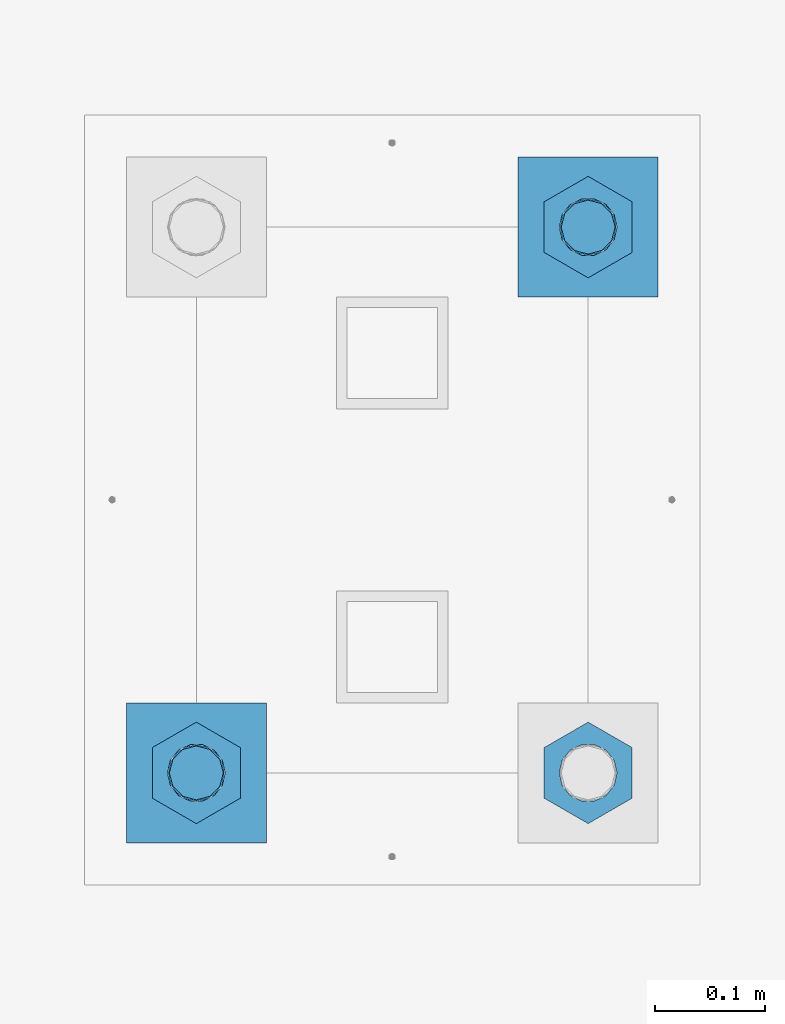
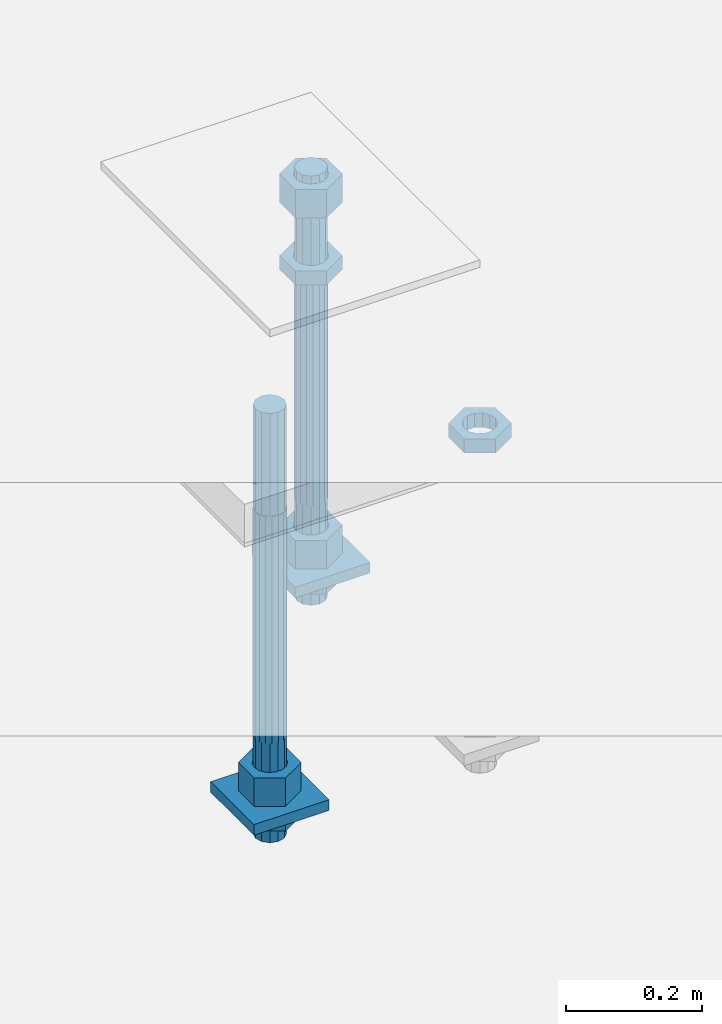
# One storey, part 2630 of 3843: 11 beams, 1 element without a shape of its own.
"""IFC2X3 building model written with IfcOpenShell, lengths in millimetres."""

from ifc_helpers import new_model, si_unit, frame, origin_with_axes, place, context, subcontext, project, spatial, faceted_brep, material, type_object, element, aggregate, save


model = new_model("IFC2X3")

# Units and contexts
model_context = context("Model", 3, precision=1e-05, world=origin_with_axes())
body_context = subcontext(model_context, "Body", "Model", "MODEL_VIEW")
ifc_project = project(units=[si_unit("LENGTHUNIT", "METRE", prefix="MILLI"), si_unit("AREAUNIT", "SQUARE_METRE"), si_unit("VOLUMEUNIT", "CUBIC_METRE"), si_unit("MASSUNIT", "GRAM", prefix="KILO"), si_unit("TIMEUNIT", "SECOND"), si_unit("PLANEANGLEUNIT", "RADIAN"), si_unit("SOLIDANGLEUNIT", "STERADIAN"), si_unit("THERMODYNAMICTEMPERATUREUNIT", "DEGREE_CELSIUS"), si_unit("LUMINOUSINTENSITYUNIT", "LUMEN")], contexts=[model_context])

# Site, building, storey
site_placement = place(None, origin_with_axes())
site = spatial("IfcSite", under=ifc_project, at=site_placement, CompositionType="ELEMENT")
building_placement = place(site_placement, origin_with_axes())
building = spatial("IfcBuilding", under=site, at=building_placement, Name="Undefined", CompositionType="ELEMENT")
storey_placement = place(building_placement, origin_with_axes())
storey = spatial("IfcBuildingStorey", under=building, at=storey_placement, Name="Undefined", CompositionType="ELEMENT", Elevation=0.0)

# Assembly, beams
assembly_placement = place(storey_placement, origin_with_axes())
assembly = element("IfcElementAssembly", 1, at=assembly_placement, inside=storey, Name="TEMPLATE", AssemblyPlace="NOTDEFINED", PredefinedType="RIGID_FRAME")
ifc_material_1 = material(Name="STEEL/A572-50")
beam_type_1 = type_object("IfcBeamType", PredefinedType="NOTDEFINED")
beam_1_placement = place(assembly_placement, frame((118605.300001526, -247.649999999994, 29244.925), z_axis=(0.0, -1.0, 0.0), x_axis=(1.0, 0.0, 0.0)))
beam_1 = element("IfcBeam", 2, at=beam_1_placement, type_object=beam_type_1, material=ifc_material_1, Name="WASHER_PLATE", context=body_context, shape_type="Brep", body=[
    faceted_brep([(0.0, 9.52500000000146, -63.5), (0.0, 9.52500000000146, 63.5), (127.0, 9.52500000000146, 63.5), (127.0, 9.52500000000146, -63.5), (0.0, -9.52500000000146, 63.5), (127.0, -9.52500000000146, 63.5), (0.0, -9.52500000000146, -63.5), (127.0, -9.52500000000146, -63.5)], [[[0, 1, 2, 3]], [[1, 4, 5, 2]], [[4, 6, 7, 5]], [[6, 0, 3, 7]], [[5, 7, 3, 2]], [[6, 4, 1, 0]]]),
])
beam_2_placement = place(assembly_placement, frame((118960.900001526, 247.649999999994, 29244.925), z_axis=(0.0, -1.0, 0.0), x_axis=(1.0, 0.0, 0.0)))
beam_2 = element("IfcBeam", 3, at=beam_2_placement, type_object=beam_type_1, material=ifc_material_1, Name="WASHER_PLATE", context=body_context, shape_type="Brep", body=[
    faceted_brep([(0.0, 9.52500000000146, -63.5), (0.0, 9.52500000000146, 63.5), (127.0, 9.52500000000146, 63.5), (127.0, 9.52500000000146, -63.5), (0.0, -9.52500000000146, 63.5), (127.0, -9.52500000000146, 63.5), (0.0, -9.52500000000146, -63.5), (127.0, -9.52500000000146, -63.5)], [[[0, 1, 2, 3]], [[1, 4, 5, 2]], [[4, 6, 7, 5]], [[6, 0, 3, 7]], [[5, 7, 3, 2]], [[6, 4, 1, 0]]]),
])
ifc_material_2 = material(Name="STEEL/A36")
beam_type_2 = type_object("IfcBeamType", Name="2_HALF_NUT", PredefinedType="NOTDEFINED")
beam_3_placement = place(assembly_placement, frame((118668.800001526, -247.649999999994, 29235.4), z_axis=(1.0, 0.0, 0.0), x_axis=(0.0, 0.0, -1.0)))
beam_3 = element("IfcBeam", 4, at=beam_3_placement, type_object=beam_type_2, material=ifc_material_2, Name="NUT", ObjectType="2_HALF_NUT", context=body_context, shape_type="Brep", body=[
    faceted_brep([(0.0, -46.0369987487793, 0.0), (0.0, -23.0184993743896, -39.869213104248), (25.4000000000015, -23.0184993743896, -39.869213104248), (25.4000000000015, -46.0369987487793, 0.0), (0.0, 23.0184993743896, -39.869213104248), (25.4000000000015, 23.0184993743896, -39.869213104248), (0.0, 46.0369987487793, 0.0), (25.4000000000015, 46.0369987487793, 0.0), (0.0, 23.0184993743896, 39.869213104248), (25.4000000000015, 23.0184993743896, 39.869213104248), (0.0, -23.0184993743896, 39.869213104248), (25.4000000000015, -23.0184993743896, 39.869213104248), (0.0, 0.0, 26.1940002441406), (0.0, 11.3650617044477, 23.5999013092805), (25.4000000000015, 11.3650617044477, 23.5999013092805), (25.4000000000015, 0.0, 26.1940002441406), (0.0, 20.4791109456419, 16.3316083006721), (25.4000000000015, 20.4791109456419, 16.3316083006721), (0.0, 25.5370200498292, 5.82867859874386), (25.4000000000015, 25.5370200498292, 5.82867859874386), (0.0, 25.5370200498292, -5.82867859874386), (25.4000000000015, 25.5370200498292, -5.82867859874386), (0.0, 20.4791109456419, -16.3316083006721), (25.4000000000015, 20.4791109456419, -16.3316083006721), (0.0, 11.3650617044477, -23.5999013092805), (25.4000000000015, 11.3650617044477, -23.5999013092805), (0.0, 0.0, -26.1940002441406), (25.4000000000015, 0.0, -26.1940002441406), (0.0, -11.3650617044477, -23.5999013092805), (25.4000000000015, -11.3650617044477, -23.5999013092805), (0.0, -20.4791109456419, -16.3316083006721), (25.4000000000015, -20.4791109456419, -16.3316083006721), (0.0, -25.5370200498292, -5.82867859874386), (25.4000000000015, -25.5370200498292, -5.82867859874386), (0.0, -25.5370200498292, 5.82867859874386), (25.4000000000015, -25.5370200498292, 5.82867859874386), (0.0, -20.4791109456419, 16.3316083006721), (25.4000000000015, -20.4791109456419, 16.3316083006721), (0.0, -11.3650617044477, 23.5999013092805), (25.4000000000015, -11.3650617044477, 23.5999013092805)], [[[0, 1, 2, 3]], [[1, 4, 5, 2]], [[4, 6, 7, 5]], [[6, 8, 9, 7]], [[8, 10, 11, 9]], [[10, 0, 3, 11]], [[12, 13, 14, 15]], [[13, 16, 17, 14]], [[16, 18, 19, 17]], [[18, 20, 21, 19]], [[20, 22, 23, 21]], [[22, 24, 25, 23]], [[24, 26, 27, 25]], [[26, 28, 29, 27]], [[28, 30, 31, 29]], [[30, 32, 33, 31]], [[32, 34, 35, 33]], [[34, 36, 37, 35]], [[36, 38, 39, 37]], [[38, 12, 15, 39]], [[5, 7, 9, 11, 3, 2], [17, 19, 21, 23, 25, 27, 29, 31, 33, 35, 37, 39, 15, 14]], [[10, 8, 6, 4, 1, 0], [38, 36, 34, 32, 30, 28, 26, 24, 22, 20, 18, 16, 13, 12]]]),
])
beam_4_placement = place(assembly_placement, frame((119024.400001526, 247.649999999994, 29787.85), z_axis=(1.0, 0.0, 0.0), x_axis=(0.0, 0.0, -1.0)))
beam_4 = element("IfcBeam", 5, at=beam_4_placement, type_object=beam_type_2, material=ifc_material_2, Name="NUT", ObjectType="2_HALF_NUT", context=body_context, shape_type="Brep", body=[
    faceted_brep([(0.0, -46.0369987487793, 0.0), (0.0, -23.0184993743896, -39.869213104248), (25.4000000000015, -23.0184993743896, -39.869213104248), (25.4000000000015, -46.0369987487793, 0.0), (0.0, 23.0184993743896, -39.869213104248), (25.4000000000015, 23.0184993743896, -39.869213104248), (0.0, 46.0369987487793, 0.0), (25.4000000000015, 46.0369987487793, 0.0), (0.0, 23.0184993743896, 39.869213104248), (25.4000000000015, 23.0184993743896, 39.869213104248), (0.0, -23.0184993743896, 39.869213104248), (25.4000000000015, -23.0184993743896, 39.869213104248), (0.0, 0.0, 26.1940002441406), (0.0, 11.3650617044477, 23.5999013092805), (25.4000000000015, 11.3650617044477, 23.5999013092805), (25.4000000000015, 0.0, 26.1940002441406), (0.0, 20.4791109456419, 16.3316083006721), (25.4000000000015, 20.4791109456419, 16.3316083006721), (0.0, 25.5370200498292, 5.82867859874386), (25.4000000000015, 25.5370200498292, 5.82867859874386), (0.0, 25.5370200498292, -5.82867859874386), (25.4000000000015, 25.5370200498292, -5.82867859874386), (0.0, 20.4791109456419, -16.3316083006721), (25.4000000000015, 20.4791109456419, -16.3316083006721), (0.0, 11.3650617044477, -23.5999013092805), (25.4000000000015, 11.3650617044477, -23.5999013092805), (0.0, 0.0, -26.1940002441406), (25.4000000000015, 0.0, -26.1940002441406), (0.0, -11.3650617044477, -23.5999013092805), (25.4000000000015, -11.3650617044477, -23.5999013092805), (0.0, -20.4791109456419, -16.3316083006721), (25.4000000000015, -20.4791109456419, -16.3316083006721), (0.0, -25.5370200498292, -5.82867859874386), (25.4000000000015, -25.5370200498292, -5.82867859874386), (0.0, -25.5370200498292, 5.82867859874386), (25.4000000000015, -25.5370200498292, 5.82867859874386), (0.0, -20.4791109456419, 16.3316083006721), (25.4000000000015, -20.4791109456419, 16.3316083006721), (0.0, -11.3650617044477, 23.5999013092805), (25.4000000000015, -11.3650617044477, 23.5999013092805)], [[[0, 1, 2, 3]], [[1, 4, 5, 2]], [[4, 6, 7, 5]], [[6, 8, 9, 7]], [[8, 10, 11, 9]], [[10, 0, 3, 11]], [[12, 13, 14, 15]], [[13, 16, 17, 14]], [[16, 18, 19, 17]], [[18, 20, 21, 19]], [[20, 22, 23, 21]], [[22, 24, 25, 23]], [[24, 26, 27, 25]], [[26, 28, 29, 27]], [[28, 30, 31, 29]], [[30, 32, 33, 31]], [[32, 34, 35, 33]], [[34, 36, 37, 35]], [[36, 38, 39, 37]], [[38, 12, 15, 39]], [[5, 7, 9, 11, 3, 2], [17, 19, 21, 23, 25, 27, 29, 31, 33, 35, 37, 39, 15, 14]], [[10, 8, 6, 4, 1, 0], [38, 36, 34, 32, 30, 28, 26, 24, 22, 20, 18, 16, 13, 12]]]),
])
beam_5_placement = place(assembly_placement, frame((119024.400001526, 247.649999999994, 29235.4), z_axis=(1.0, 0.0, 0.0), x_axis=(0.0, 0.0, -1.0)))
beam_5 = element("IfcBeam", 6, at=beam_5_placement, type_object=beam_type_2, material=ifc_material_2, Name="NUT", ObjectType="2_HALF_NUT", context=body_context, shape_type="Brep", body=[
    faceted_brep([(0.0, -46.0369987487793, 0.0), (0.0, -23.0184993743896, -39.869213104248), (25.4000000000015, -23.0184993743896, -39.869213104248), (25.4000000000015, -46.0369987487793, 0.0), (0.0, 23.0184993743896, -39.869213104248), (25.4000000000015, 23.0184993743896, -39.869213104248), (0.0, 46.0369987487793, 0.0), (25.4000000000015, 46.0369987487793, 0.0), (0.0, 23.0184993743896, 39.869213104248), (25.4000000000015, 23.0184993743896, 39.869213104248), (0.0, -23.0184993743896, 39.869213104248), (25.4000000000015, -23.0184993743896, 39.869213104248), (0.0, 0.0, 26.1940002441406), (0.0, 11.3650617044477, 23.5999013092805), (25.4000000000015, 11.3650617044477, 23.5999013092805), (25.4000000000015, 0.0, 26.1940002441406), (0.0, 20.4791109456419, 16.3316083006721), (25.4000000000015, 20.4791109456419, 16.3316083006721), (0.0, 25.5370200498292, 5.82867859874386), (25.4000000000015, 25.5370200498292, 5.82867859874386), (0.0, 25.5370200498292, -5.82867859874386), (25.4000000000015, 25.5370200498292, -5.82867859874386), (0.0, 20.4791109456419, -16.3316083006721), (25.4000000000015, 20.4791109456419, -16.3316083006721), (0.0, 11.3650617044477, -23.5999013092805), (25.4000000000015, 11.3650617044477, -23.5999013092805), (0.0, 0.0, -26.1940002441406), (25.4000000000015, 0.0, -26.1940002441406), (0.0, -11.3650617044477, -23.5999013092805), (25.4000000000015, -11.3650617044477, -23.5999013092805), (0.0, -20.4791109456419, -16.3316083006721), (25.4000000000015, -20.4791109456419, -16.3316083006721), (0.0, -25.5370200498292, -5.82867859874386), (25.4000000000015, -25.5370200498292, -5.82867859874386), (0.0, -25.5370200498292, 5.82867859874386), (25.4000000000015, -25.5370200498292, 5.82867859874386), (0.0, -20.4791109456419, 16.3316083006721), (25.4000000000015, -20.4791109456419, 16.3316083006721), (0.0, -11.3650617044477, 23.5999013092805), (25.4000000000015, -11.3650617044477, 23.5999013092805)], [[[0, 1, 2, 3]], [[1, 4, 5, 2]], [[4, 6, 7, 5]], [[6, 8, 9, 7]], [[8, 10, 11, 9]], [[10, 0, 3, 11]], [[12, 13, 14, 15]], [[13, 16, 17, 14]], [[16, 18, 19, 17]], [[18, 20, 21, 19]], [[20, 22, 23, 21]], [[22, 24, 25, 23]], [[24, 26, 27, 25]], [[26, 28, 29, 27]], [[28, 30, 31, 29]], [[30, 32, 33, 31]], [[32, 34, 35, 33]], [[34, 36, 37, 35]], [[36, 38, 39, 37]], [[38, 12, 15, 39]], [[5, 7, 9, 11, 3, 2], [17, 19, 21, 23, 25, 27, 29, 31, 33, 35, 37, 39, 15, 14]], [[10, 8, 6, 4, 1, 0], [38, 36, 34, 32, 30, 28, 26, 24, 22, 20, 18, 16, 13, 12]]]),
])
beam_6_placement = place(assembly_placement, frame((119024.400001526, -247.649999999994, 29787.85), z_axis=(1.0, 0.0, 0.0), x_axis=(0.0, 0.0, -1.0)))
beam_6 = element("IfcBeam", 7, at=beam_6_placement, type_object=beam_type_2, material=ifc_material_2, Name="NUT", ObjectType="2_HALF_NUT", context=body_context, shape_type="Brep", body=[
    faceted_brep([(0.0, -46.0369987487793, 0.0), (0.0, -23.0184993743896, -39.869213104248), (25.4000000000015, -23.0184993743896, -39.869213104248), (25.4000000000015, -46.0369987487793, 0.0), (0.0, 23.0184993743896, -39.869213104248), (25.4000000000015, 23.0184993743896, -39.869213104248), (0.0, 46.0369987487793, 0.0), (25.4000000000015, 46.0369987487793, 0.0), (0.0, 23.0184993743896, 39.869213104248), (25.4000000000015, 23.0184993743896, 39.869213104248), (0.0, -23.0184993743896, 39.869213104248), (25.4000000000015, -23.0184993743896, 39.869213104248), (0.0, 0.0, 26.1940002441406), (0.0, 11.3650617044477, 23.5999013092805), (25.4000000000015, 11.3650617044477, 23.5999013092805), (25.4000000000015, 0.0, 26.1940002441406), (0.0, 20.4791109456419, 16.3316083006721), (25.4000000000015, 20.4791109456419, 16.3316083006721), (0.0, 25.5370200498292, 5.82867859874386), (25.4000000000015, 25.5370200498292, 5.82867859874386), (0.0, 25.5370200498292, -5.82867859874386), (25.4000000000015, 25.5370200498292, -5.82867859874386), (0.0, 20.4791109456419, -16.3316083006721), (25.4000000000015, 20.4791109456419, -16.3316083006721), (0.0, 11.3650617044477, -23.5999013092805), (25.4000000000015, 11.3650617044477, -23.5999013092805), (0.0, 0.0, -26.1940002441406), (25.4000000000015, 0.0, -26.1940002441406), (0.0, -11.3650617044477, -23.5999013092805), (25.4000000000015, -11.3650617044477, -23.5999013092805), (0.0, -20.4791109456419, -16.3316083006721), (25.4000000000015, -20.4791109456419, -16.3316083006721), (0.0, -25.5370200498292, -5.82867859874386), (25.4000000000015, -25.5370200498292, -5.82867859874386), (0.0, -25.5370200498292, 5.82867859874386), (25.4000000000015, -25.5370200498292, 5.82867859874386), (0.0, -20.4791109456419, 16.3316083006721), (25.4000000000015, -20.4791109456419, 16.3316083006721), (0.0, -11.3650617044477, 23.5999013092805), (25.4000000000015, -11.3650617044477, 23.5999013092805)], [[[0, 1, 2, 3]], [[1, 4, 5, 2]], [[4, 6, 7, 5]], [[6, 8, 9, 7]], [[8, 10, 11, 9]], [[10, 0, 3, 11]], [[12, 13, 14, 15]], [[13, 16, 17, 14]], [[16, 18, 19, 17]], [[18, 20, 21, 19]], [[20, 22, 23, 21]], [[22, 24, 25, 23]], [[24, 26, 27, 25]], [[26, 28, 29, 27]], [[28, 30, 31, 29]], [[30, 32, 33, 31]], [[32, 34, 35, 33]], [[34, 36, 37, 35]], [[36, 38, 39, 37]], [[38, 12, 15, 39]], [[5, 7, 9, 11, 3, 2], [17, 19, 21, 23, 25, 27, 29, 31, 33, 35, 37, 39, 15, 14]], [[10, 8, 6, 4, 1, 0], [38, 36, 34, 32, 30, 28, 26, 24, 22, 20, 18, 16, 13, 12]]]),
])
beam_type_3 = type_object("IfcBeamType", Name="2_HEAVY_HEX_NUT", PredefinedType="NOTDEFINED")
beam_7_placement = place(assembly_placement, frame((118668.800001526, -247.649999999994, 29305.25), z_axis=(1.0, 0.0, 0.0), x_axis=(0.0, 0.0, -1.0)))
beam_7 = element("IfcBeam", 8, at=beam_7_placement, type_object=beam_type_3, material=ifc_material_2, Name="NUT", ObjectType="2_HEAVY_HEX_NUT", context=body_context, shape_type="Brep", body=[
    faceted_brep([(0.0, -46.0369987487793, 0.0), (0.0, -23.0184993743896, -39.869213104248), (50.7999999999993, -23.0184993743896, -39.869213104248), (50.7999999999993, -46.0369987487793, 0.0), (0.0, 23.0184993743896, -39.869213104248), (50.7999999999993, 23.0184993743896, -39.869213104248), (0.0, 46.0369987487793, 0.0), (50.7999999999993, 46.0369987487793, 0.0), (0.0, 23.0184993743896, 39.869213104248), (50.7999999999993, 23.0184993743896, 39.869213104248), (0.0, -23.0184993743896, 39.869213104248), (50.7999999999993, -23.0184993743896, 39.869213104248), (0.0, 0.0, 26.1940002441406), (0.0, 11.3650617044477, 23.5999013092805), (50.7999999999993, 11.3650617044477, 23.5999013092805), (50.7999999999993, 0.0, 26.1940002441406), (0.0, 20.4791109456419, 16.3316083006721), (50.7999999999993, 20.4791109456419, 16.3316083006721), (0.0, 25.5370200498292, 5.82867859874386), (50.7999999999993, 25.5370200498292, 5.82867859874386), (0.0, 25.5370200498292, -5.82867859874386), (50.7999999999993, 25.5370200498292, -5.82867859874386), (0.0, 20.4791109456419, -16.3316083006721), (50.7999999999993, 20.4791109456419, -16.3316083006721), (0.0, 11.3650617044477, -23.5999013092805), (50.7999999999993, 11.3650617044477, -23.5999013092805), (0.0, 0.0, -26.1940002441406), (50.7999999999993, 0.0, -26.1940002441406), (0.0, -11.3650617044477, -23.5999013092805), (50.7999999999993, -11.3650617044477, -23.5999013092805), (0.0, -20.4791109456419, -16.3316083006721), (50.7999999999993, -20.4791109456419, -16.3316083006721), (0.0, -25.5370200498292, -5.82867859874386), (50.7999999999993, -25.5370200498292, -5.82867859874386), (0.0, -25.5370200498292, 5.82867859874386), (50.7999999999993, -25.5370200498292, 5.82867859874386), (0.0, -20.4791109456419, 16.3316083006721), (50.7999999999993, -20.4791109456419, 16.3316083006721), (0.0, -11.3650617044477, 23.5999013092805), (50.7999999999993, -11.3650617044477, 23.5999013092805)], [[[0, 1, 2, 3]], [[1, 4, 5, 2]], [[4, 6, 7, 5]], [[6, 8, 9, 7]], [[8, 10, 11, 9]], [[10, 0, 3, 11]], [[12, 13, 14, 15]], [[13, 16, 17, 14]], [[16, 18, 19, 17]], [[18, 20, 21, 19]], [[20, 22, 23, 21]], [[22, 24, 25, 23]], [[24, 26, 27, 25]], [[26, 28, 29, 27]], [[28, 30, 31, 29]], [[30, 32, 33, 31]], [[32, 34, 35, 33]], [[34, 36, 37, 35]], [[36, 38, 39, 37]], [[38, 12, 15, 39]], [[5, 7, 9, 11, 3, 2], [17, 19, 21, 23, 25, 27, 29, 31, 33, 35, 37, 39, 15, 14]], [[10, 8, 6, 4, 1, 0], [38, 36, 34, 32, 30, 28, 26, 24, 22, 20, 18, 16, 13, 12]]]),
])
beam_8_placement = place(assembly_placement, frame((119024.400001526, 247.649999999994, 29933.9), z_axis=(1.0, 0.0, 0.0), x_axis=(0.0, 0.0, -1.0)))
beam_8 = element("IfcBeam", 9, at=beam_8_placement, type_object=beam_type_3, material=ifc_material_2, Name="NUT", ObjectType="2_HEAVY_HEX_NUT", context=body_context, shape_type="Brep", body=[
    faceted_brep([(0.0, -46.0369987487793, 0.0), (0.0, -23.0184993743896, -39.869213104248), (50.7999999999993, -23.0184993743896, -39.869213104248), (50.7999999999993, -46.0369987487793, 0.0), (0.0, 23.0184993743896, -39.869213104248), (50.7999999999993, 23.0184993743896, -39.869213104248), (0.0, 46.0369987487793, 0.0), (50.7999999999993, 46.0369987487793, 0.0), (0.0, 23.0184993743896, 39.869213104248), (50.7999999999993, 23.0184993743896, 39.869213104248), (0.0, -23.0184993743896, 39.869213104248), (50.7999999999993, -23.0184993743896, 39.869213104248), (0.0, 0.0, 26.1940002441406), (0.0, 11.3650617044477, 23.5999013092805), (50.7999999999993, 11.3650617044477, 23.5999013092805), (50.7999999999993, 0.0, 26.1940002441406), (0.0, 20.4791109456419, 16.3316083006721), (50.7999999999993, 20.4791109456419, 16.3316083006721), (0.0, 25.5370200498292, 5.82867859874386), (50.7999999999993, 25.5370200498292, 5.82867859874386), (0.0, 25.5370200498292, -5.82867859874386), (50.7999999999993, 25.5370200498292, -5.82867859874386), (0.0, 20.4791109456419, -16.3316083006721), (50.7999999999993, 20.4791109456419, -16.3316083006721), (0.0, 11.3650617044477, -23.5999013092805), (50.7999999999993, 11.3650617044477, -23.5999013092805), (0.0, 0.0, -26.1940002441406), (50.7999999999993, 0.0, -26.1940002441406), (0.0, -11.3650617044477, -23.5999013092805), (50.7999999999993, -11.3650617044477, -23.5999013092805), (0.0, -20.4791109456419, -16.3316083006721), (50.7999999999993, -20.4791109456419, -16.3316083006721), (0.0, -25.5370200498292, -5.82867859874386), (50.7999999999993, -25.5370200498292, -5.82867859874386), (0.0, -25.5370200498292, 5.82867859874386), (50.7999999999993, -25.5370200498292, 5.82867859874386), (0.0, -20.4791109456419, 16.3316083006721), (50.7999999999993, -20.4791109456419, 16.3316083006721), (0.0, -11.3650617044477, 23.5999013092805), (50.7999999999993, -11.3650617044477, 23.5999013092805)], [[[0, 1, 2, 3]], [[1, 4, 5, 2]], [[4, 6, 7, 5]], [[6, 8, 9, 7]], [[8, 10, 11, 9]], [[10, 0, 3, 11]], [[12, 13, 14, 15]], [[13, 16, 17, 14]], [[16, 18, 19, 17]], [[18, 20, 21, 19]], [[20, 22, 23, 21]], [[22, 24, 25, 23]], [[24, 26, 27, 25]], [[26, 28, 29, 27]], [[28, 30, 31, 29]], [[30, 32, 33, 31]], [[32, 34, 35, 33]], [[34, 36, 37, 35]], [[36, 38, 39, 37]], [[38, 12, 15, 39]], [[5, 7, 9, 11, 3, 2], [17, 19, 21, 23, 25, 27, 29, 31, 33, 35, 37, 39, 15, 14]], [[10, 8, 6, 4, 1, 0], [38, 36, 34, 32, 30, 28, 26, 24, 22, 20, 18, 16, 13, 12]]]),
])
beam_9_placement = place(assembly_placement, frame((119024.400001526, 247.649999999994, 29305.25), z_axis=(1.0, 0.0, 0.0), x_axis=(0.0, 0.0, -1.0)))
beam_9 = element("IfcBeam", 10, at=beam_9_placement, type_object=beam_type_3, material=ifc_material_2, Name="NUT", ObjectType="2_HEAVY_HEX_NUT", context=body_context, shape_type="Brep", body=[
    faceted_brep([(0.0, -46.0369987487793, 0.0), (0.0, -23.0184993743896, -39.869213104248), (50.7999999999993, -23.0184993743896, -39.869213104248), (50.7999999999993, -46.0369987487793, 0.0), (0.0, 23.0184993743896, -39.869213104248), (50.7999999999993, 23.0184993743896, -39.869213104248), (0.0, 46.0369987487793, 0.0), (50.7999999999993, 46.0369987487793, 0.0), (0.0, 23.0184993743896, 39.869213104248), (50.7999999999993, 23.0184993743896, 39.869213104248), (0.0, -23.0184993743896, 39.869213104248), (50.7999999999993, -23.0184993743896, 39.869213104248), (0.0, 0.0, 26.1940002441406), (0.0, 11.3650617044477, 23.5999013092805), (50.7999999999993, 11.3650617044477, 23.5999013092805), (50.7999999999993, 0.0, 26.1940002441406), (0.0, 20.4791109456419, 16.3316083006721), (50.7999999999993, 20.4791109456419, 16.3316083006721), (0.0, 25.5370200498292, 5.82867859874386), (50.7999999999993, 25.5370200498292, 5.82867859874386), (0.0, 25.5370200498292, -5.82867859874386), (50.7999999999993, 25.5370200498292, -5.82867859874386), (0.0, 20.4791109456419, -16.3316083006721), (50.7999999999993, 20.4791109456419, -16.3316083006721), (0.0, 11.3650617044477, -23.5999013092805), (50.7999999999993, 11.3650617044477, -23.5999013092805), (0.0, 0.0, -26.1940002441406), (50.7999999999993, 0.0, -26.1940002441406), (0.0, -11.3650617044477, -23.5999013092805), (50.7999999999993, -11.3650617044477, -23.5999013092805), (0.0, -20.4791109456419, -16.3316083006721), (50.7999999999993, -20.4791109456419, -16.3316083006721), (0.0, -25.5370200498292, -5.82867859874386), (50.7999999999993, -25.5370200498292, -5.82867859874386), (0.0, -25.5370200498292, 5.82867859874386), (50.7999999999993, -25.5370200498292, 5.82867859874386), (0.0, -20.4791109456419, 16.3316083006721), (50.7999999999993, -20.4791109456419, 16.3316083006721), (0.0, -11.3650617044477, 23.5999013092805), (50.7999999999993, -11.3650617044477, 23.5999013092805)], [[[0, 1, 2, 3]], [[1, 4, 5, 2]], [[4, 6, 7, 5]], [[6, 8, 9, 7]], [[8, 10, 11, 9]], [[10, 0, 3, 11]], [[12, 13, 14, 15]], [[13, 16, 17, 14]], [[16, 18, 19, 17]], [[18, 20, 21, 19]], [[20, 22, 23, 21]], [[22, 24, 25, 23]], [[24, 26, 27, 25]], [[26, 28, 29, 27]], [[28, 30, 31, 29]], [[30, 32, 33, 31]], [[32, 34, 35, 33]], [[34, 36, 37, 35]], [[36, 38, 39, 37]], [[38, 12, 15, 39]], [[5, 7, 9, 11, 3, 2], [17, 19, 21, 23, 25, 27, 29, 31, 33, 35, 37, 39, 15, 14]], [[10, 8, 6, 4, 1, 0], [38, 36, 34, 32, 30, 28, 26, 24, 22, 20, 18, 16, 13, 12]]]),
])
ifc_material_3 = material()
beam_type_4 = type_object("IfcBeamType", PredefinedType="NOTDEFINED")
beam_10_placement = place(assembly_placement, frame((118668.800001526, -247.649999999994, 29762.45), z_axis=(1.0, 0.0, 0.0), x_axis=(0.0, 0.0, -1.0)))
beam_10 = element("IfcBeam", 11, at=beam_10_placement, type_object=beam_type_4, material=ifc_material_3, Name="ANCHOR_ROD", context=body_context, shape_type="Brep", body=[
    faceted_brep([(-184.150000000001, -21.217622392709, 12.25), (-184.150000000001, -12.2499999999854, 21.2176223927163), (-184.150000000001, 1.45519152283669e-11, 24.5), (-184.150000000001, 12.2500000000146, 21.2176223927163), (-184.150000000001, 21.2176223927381, 12.25), (-184.150000000001, 24.5000000000146, 0.0), (-184.150000000001, 21.2176223927381, -12.25), (-184.150000000001, 12.2500000000146, -21.2176223927163), (-184.150000000001, 1.45519152283669e-11, -24.5), (-184.150000000001, -12.2499999999854, -21.2176223927163), (-184.150000000001, -21.217622392709, -12.25), (-184.150000000001, -24.4999999999854, 0.0), (0.0, 24.5000000000146, 0.0), (0.0, 21.2176223927381, -12.25), (0.0, 12.2500000000146, -21.2176223927163), (0.0, 1.45519152283669e-11, -24.5), (0.0, -12.2499999999854, -21.2176223927163), (0.0, -21.217622392709, -12.25), (0.0, -24.4999999999854, 0.0), (0.0, -21.217622392709, 12.25), (0.0, -12.2499999999854, 21.2176223927163), (0.0, 1.45519152283669e-11, 24.5), (0.0, 12.2500000000146, 21.2176223927163), (0.0, 21.2176223927381, 12.25), (0.0, -23.4665401257807, 9.72015918207035), (0.0, -17.9605122421344, 17.9605122421417), (0.0, -9.72015918207762, 23.466540125788), (0.0, 0.0, 25.4000000000015), (0.0, 9.72015918207762, 23.466540125788), (0.0, 17.9605122421344, 17.9605122421417), (0.0, 23.4665401257807, 9.72015918207035), (0.0, 25.3999996185303, 0.0), (0.0, 23.4665401257807, -9.72015918207035), (0.0, 17.9605122421344, -17.9605122421417), (0.0, 9.72015918207762, -23.466540125788), (0.0, 0.0, -25.4000000000015), (0.0, -9.72015918207762, -23.466540125788), (0.0, -17.9605122421344, -17.9605122421417), (0.0, -23.4665401257807, -9.72015918207035), (0.0, -25.3999996185303, 0.0), (406.399999999998, -25.3999999999942, 0.0), (406.399999999998, -23.4665401257807, 9.72015918207035), (406.399999999998, -17.9605122421344, 17.9605122421417), (406.399999999998, -9.72015918207762, 23.466540125788), (406.399999999998, 0.0, 25.4000000000015), (406.399999999998, 9.72015918207762, 23.466540125788), (406.399999999998, 17.9605122421344, 17.9605122421417), (406.399999999998, 23.4665401257807, 9.72015918207035), (406.399999999998, 25.3999999999942, 0.0), (406.399999999998, 23.4665401257807, -9.72015918207035), (406.399999999998, 17.9605122421344, -17.9605122421417), (406.399999999998, 9.72015918207762, -23.466540125788), (406.399999999998, 0.0, -25.4000000000015), (406.399999999998, -9.72015918207762, -23.466540125788), (406.399999999998, -17.9605122421344, -17.9605122421417), (406.399999999998, -23.4665401257807, -9.72015918207035), (406.399999999998, -12.2499999999854, 21.2176223927163), (406.399999999998, 1.45519152283669e-11, 24.5), (406.399999999998, 12.2500000000146, 21.2176223927163), (406.399999999998, 21.2176223927381, 12.25), (406.399999999998, 24.5000000000146, 0.0), (406.399999999998, 21.2176223927381, -12.25), (406.399999999998, 12.2500000000146, -21.2176223927163), (406.399999999998, 1.45519152283669e-11, -24.5), (406.399999999998, -12.2499999999854, -21.2176223927163), (406.399999999998, -21.217622392709, -12.25), (406.399999999998, -24.4999999999854, 0.0), (406.399999999998, -21.217622392709, 12.25), (584.200000000001, -12.2499999999854, -21.2176223927163), (584.200000000001, 1.45519152283669e-11, -24.5), (584.200000000001, 12.2500000000146, -21.2176223927163), (584.200000000001, 21.2176223927381, -12.25), (584.200000000001, 24.5000000000146, 0.0), (584.200000000001, 21.2176223927381, 12.25), (584.200000000001, 12.2500000000146, 21.2176223927163), (584.200000000001, 1.45519152283669e-11, 24.5), (584.200000000001, -12.2499999999854, 21.2176223927163), (584.200000000001, -21.217622392709, 12.25), (584.200000000001, -24.4999999999854, 0.0), (584.200000000001, -21.217622392709, -12.25)], [[[0, 1, 2, 3, 4, 5, 6, 7, 8, 9, 10, 11]], [[6, 5, 12, 13]], [[7, 6, 13, 14]], [[8, 7, 14, 15]], [[9, 8, 15, 16]], [[10, 9, 16, 17]], [[11, 10, 17, 18]], [[0, 11, 18, 19]], [[1, 0, 19, 20]], [[2, 1, 20, 21]], [[3, 2, 21, 22]], [[4, 3, 22, 23]], [[5, 4, 23, 12]], [[24, 25, 26, 27, 28, 29, 30, 31, 32, 33, 34, 35, 36, 37, 38, 39], [22, 21, 20, 19, 18, 17, 16, 15, 14, 13, 12, 23]], [[24, 39, 40, 41]], [[25, 24, 41, 42]], [[26, 25, 42, 43]], [[27, 26, 43, 44]], [[28, 27, 44, 45]], [[29, 28, 45, 46]], [[30, 29, 46, 47]], [[31, 30, 47, 48]], [[32, 31, 48, 49]], [[33, 32, 49, 50]], [[34, 33, 50, 51]], [[35, 34, 51, 52]], [[36, 35, 52, 53]], [[37, 36, 53, 54]], [[38, 37, 54, 55]], [[39, 38, 55, 40]], [[54, 53, 52, 51, 50, 49, 48, 47, 46, 45, 44, 43, 42, 41, 40, 55], [56, 57, 58, 59, 60, 61, 62, 63, 64, 65, 66, 67]], [[68, 69, 70, 71, 72, 73, 74, 75, 76, 77, 78, 79]], [[76, 75, 57, 56]], [[77, 76, 56, 67]], [[78, 77, 67, 66]], [[79, 78, 66, 65]], [[68, 79, 65, 64]], [[69, 68, 64, 63]], [[70, 69, 63, 62]], [[71, 70, 62, 61]], [[72, 71, 61, 60]], [[73, 72, 60, 59]], [[74, 73, 59, 58]], [[75, 74, 58, 57]]]),
])
beam_11_placement = place(assembly_placement, frame((119024.400001526, 247.649999999994, 29762.45), z_axis=(1.0, 0.0, 0.0), x_axis=(0.0, 0.0, -1.0)))
beam_11 = element("IfcBeam", 12, at=beam_11_placement, type_object=beam_type_4, material=ifc_material_3, Name="ANCHOR_ROD", context=body_context, shape_type="Brep", body=[
    faceted_brep([(-184.150000000001, -21.217622392709, 12.25), (-184.150000000001, -12.2499999999854, 21.2176223927163), (-184.150000000001, 1.45519152283669e-11, 24.5), (-184.150000000001, 12.2500000000146, 21.2176223927163), (-184.150000000001, 21.2176223927381, 12.25), (-184.150000000001, 24.5000000000146, 0.0), (-184.150000000001, 21.2176223927381, -12.25), (-184.150000000001, 12.2500000000146, -21.2176223927163), (-184.150000000001, 1.45519152283669e-11, -24.5), (-184.150000000001, -12.2499999999854, -21.2176223927163), (-184.150000000001, -21.217622392709, -12.25), (-184.150000000001, -24.4999999999854, 0.0), (0.0, 24.5000000000146, 0.0), (0.0, 21.2176223927381, -12.25), (0.0, 12.2500000000146, -21.2176223927163), (0.0, 1.45519152283669e-11, -24.5), (0.0, -12.2499999999854, -21.2176223927163), (0.0, -21.217622392709, -12.25), (0.0, -24.4999999999854, 0.0), (0.0, -21.217622392709, 12.25), (0.0, -12.2499999999854, 21.2176223927163), (0.0, 1.45519152283669e-11, 24.5), (0.0, 12.2500000000146, 21.2176223927163), (0.0, 21.2176223927381, 12.25), (0.0, -23.4665401257807, 9.72015918207035), (0.0, -17.9605122421344, 17.9605122421417), (0.0, -9.72015918207762, 23.466540125788), (0.0, 0.0, 25.4000000000015), (0.0, 9.72015918207762, 23.466540125788), (0.0, 17.9605122421344, 17.9605122421417), (0.0, 23.4665401257807, 9.72015918207035), (0.0, 25.3999996185303, 0.0), (0.0, 23.4665401257807, -9.72015918207035), (0.0, 17.9605122421344, -17.9605122421417), (0.0, 9.72015918207762, -23.466540125788), (0.0, 0.0, -25.4000000000015), (0.0, -9.72015918207762, -23.466540125788), (0.0, -17.9605122421344, -17.9605122421417), (0.0, -23.4665401257807, -9.72015918207035), (0.0, -25.3999996185303, 0.0), (406.399999999998, -25.3999999999942, 0.0), (406.399999999998, -23.4665401257807, 9.72015918207035), (406.399999999998, -17.9605122421344, 17.9605122421417), (406.399999999998, -9.72015918207762, 23.466540125788), (406.399999999998, 0.0, 25.4000000000015), (406.399999999998, 9.72015918207762, 23.466540125788), (406.399999999998, 17.9605122421344, 17.9605122421417), (406.399999999998, 23.4665401257807, 9.72015918207035), (406.399999999998, 25.3999999999942, 0.0), (406.399999999998, 23.4665401257807, -9.72015918207035), (406.399999999998, 17.9605122421344, -17.9605122421417), (406.399999999998, 9.72015918207762, -23.466540125788), (406.399999999998, 0.0, -25.4000000000015), (406.399999999998, -9.72015918207762, -23.466540125788), (406.399999999998, -17.9605122421344, -17.9605122421417), (406.399999999998, -23.4665401257807, -9.72015918207035), (406.399999999998, -12.2499999999854, 21.2176223927163), (406.399999999998, 1.45519152283669e-11, 24.5), (406.399999999998, 12.2500000000146, 21.2176223927163), (406.399999999998, 21.2176223927381, 12.25), (406.399999999998, 24.5000000000146, 0.0), (406.399999999998, 21.2176223927381, -12.25), (406.399999999998, 12.2500000000146, -21.2176223927163), (406.399999999998, 1.45519152283669e-11, -24.5), (406.399999999998, -12.2499999999854, -21.2176223927163), (406.399999999998, -21.217622392709, -12.25), (406.399999999998, -24.4999999999854, 0.0), (406.399999999998, -21.217622392709, 12.25), (584.200000000001, -12.2499999999854, -21.2176223927163), (584.200000000001, 1.45519152283669e-11, -24.5), (584.200000000001, 12.2500000000146, -21.2176223927163), (584.200000000001, 21.2176223927381, -12.25), (584.200000000001, 24.5000000000146, 0.0), (584.200000000001, 21.2176223927381, 12.25), (584.200000000001, 12.2500000000146, 21.2176223927163), (584.200000000001, 1.45519152283669e-11, 24.5), (584.200000000001, -12.2499999999854, 21.2176223927163), (584.200000000001, -21.217622392709, 12.25), (584.200000000001, -24.4999999999854, 0.0), (584.200000000001, -21.217622392709, -12.25)], [[[0, 1, 2, 3, 4, 5, 6, 7, 8, 9, 10, 11]], [[6, 5, 12, 13]], [[7, 6, 13, 14]], [[8, 7, 14, 15]], [[9, 8, 15, 16]], [[10, 9, 16, 17]], [[11, 10, 17, 18]], [[0, 11, 18, 19]], [[1, 0, 19, 20]], [[2, 1, 20, 21]], [[3, 2, 21, 22]], [[4, 3, 22, 23]], [[5, 4, 23, 12]], [[24, 25, 26, 27, 28, 29, 30, 31, 32, 33, 34, 35, 36, 37, 38, 39], [22, 21, 20, 19, 18, 17, 16, 15, 14, 13, 12, 23]], [[24, 39, 40, 41]], [[25, 24, 41, 42]], [[26, 25, 42, 43]], [[27, 26, 43, 44]], [[28, 27, 44, 45]], [[29, 28, 45, 46]], [[30, 29, 46, 47]], [[31, 30, 47, 48]], [[32, 31, 48, 49]], [[33, 32, 49, 50]], [[34, 33, 50, 51]], [[35, 34, 51, 52]], [[36, 35, 52, 53]], [[37, 36, 53, 54]], [[38, 37, 54, 55]], [[39, 38, 55, 40]], [[54, 53, 52, 51, 50, 49, 48, 47, 46, 45, 44, 43, 42, 41, 40, 55], [56, 57, 58, 59, 60, 61, 62, 63, 64, 65, 66, 67]], [[68, 69, 70, 71, 72, 73, 74, 75, 76, 77, 78, 79]], [[76, 75, 57, 56]], [[77, 76, 56, 67]], [[78, 77, 67, 66]], [[79, 78, 66, 65]], [[68, 79, 65, 64]], [[69, 68, 64, 63]], [[70, 69, 63, 62]], [[71, 70, 62, 61]], [[72, 71, 61, 60]], [[73, 72, 60, 59]], [[74, 73, 59, 58]], [[75, 74, 58, 57]]]),
])
aggregate(assembly, [beam_7, beam_3, beam_1, beam_10, beam_4, beam_8, beam_9, beam_5, beam_2, beam_11, beam_6])

save(model, "model.ifc")
